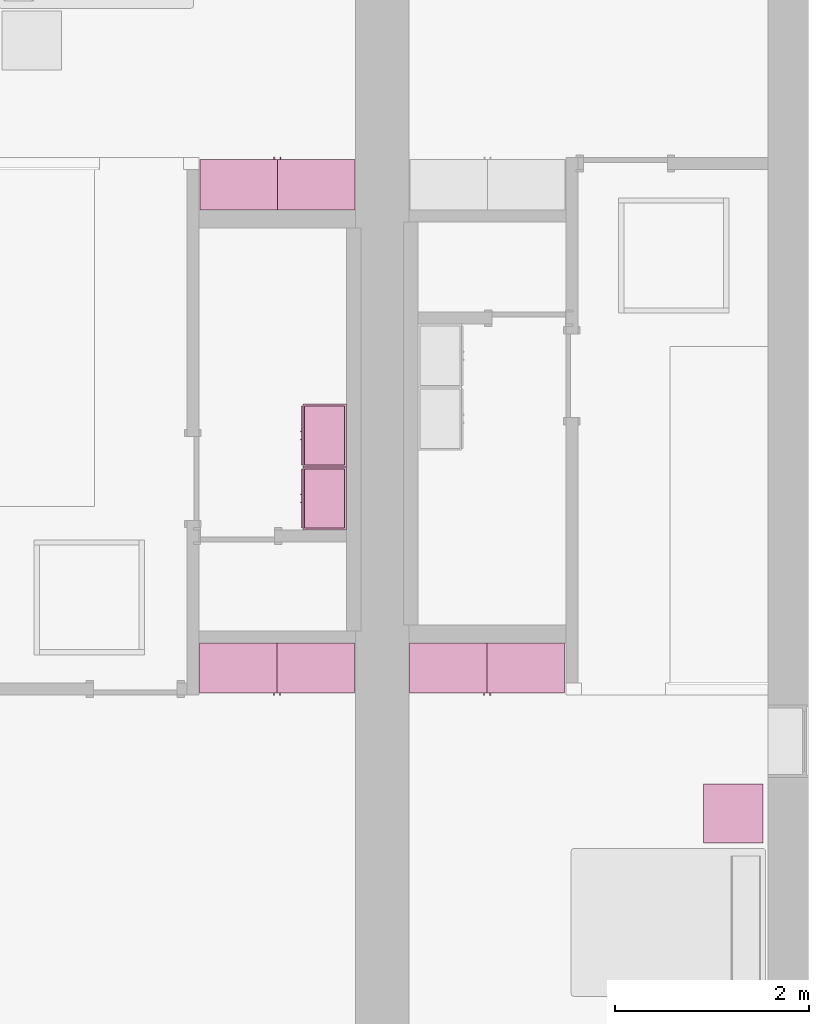
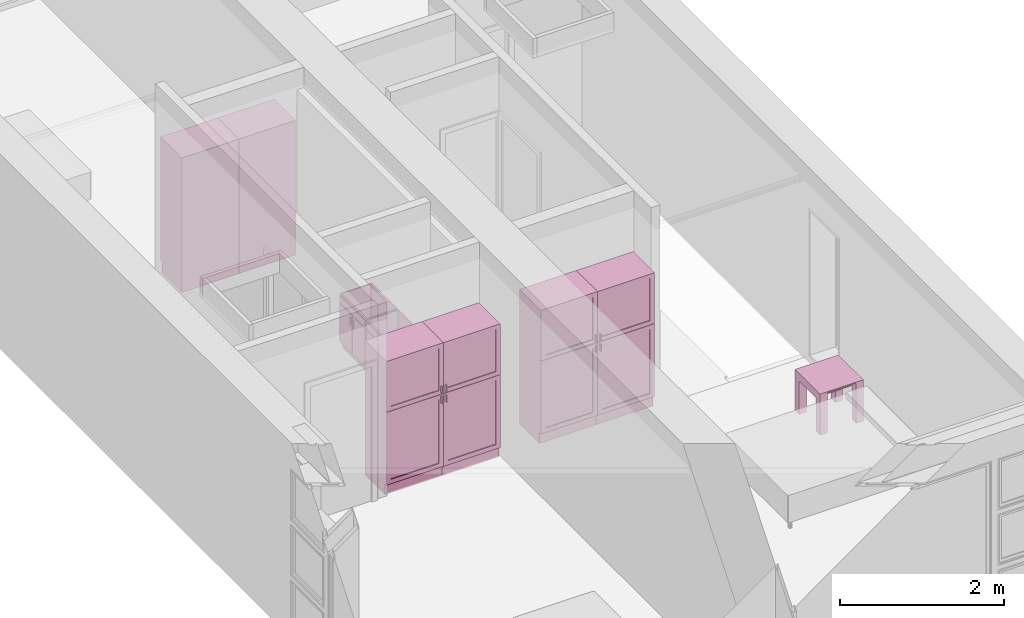
# One storey, part 10 of 14: 9 furnishings, 6 openings.
"""IFC2X3 building model written with IfcOpenShell, lengths in metres."""

from ifc_helpers import new_model, entity, si_unit, converted_unit, frame, origin, origin_2d_with_axis, place, context, project, spatial, polyline, rectangle, outline, extrude, face_set, surface_model, source, transform, mapped, type_object, type_shapes, element, save


model = new_model("IFC2X3")

# Units and contexts
model_context = context("Model", 3, precision=1e-09, world=origin())
plan_context = context("Plan", 3, precision=1e-09, world=origin())
ifc_project = project(units=[si_unit("LENGTHUNIT", "METRE"), si_unit("AREAUNIT", "SQUARE_METRE"), si_unit("VOLUMEUNIT", "CUBIC_METRE"), converted_unit("PLANEANGLEUNIT", "DEGREE", entity("IfcRatioMeasure", 0.01745329251994328), si_unit("PLANEANGLEUNIT", "RADIAN"), dimensions=[0, 0, 0, 0, 0, 0, 0]), si_unit("TIMEUNIT", "SECOND")], contexts=[model_context, plan_context])

# Site, building, storey, space
site_placement = place(None, origin())
site = spatial("IfcSite", under=ifc_project, at=site_placement, CompositionType="ELEMENT")
building_placement = place(site_placement, origin())
building = spatial("IfcBuilding", under=site, at=building_placement, CompositionType="ELEMENT")
storey_placement = place(building_placement, frame((0.0, 0.0, 3.100000000000378)))
storey = spatial("IfcBuildingStorey", under=building, at=storey_placement, Name="Level 2", CompositionType="ELEMENT", Elevation=3.100000000000378)
space_1_placement = place(storey_placement, origin())
space_1 = spatial("IfcSpace", under=storey, at=space_1_placement, CompositionType="ELEMENT", InteriorOrExteriorSpace="INTERNAL")

# Furnishing
furniture_type_1 = type_object("IfcFurnitureType", Name="0610 x 0610 x 0610mm", AssemblyPlace="NOTDEFINED")
shared_shape_1 = source(origin(), model_context, "Body", "SweptSolid", [
    extrude(rectangle(XDim=0.4067999999999992, YDim=0.4067999999999995, at=origin_2d_with_axis()), frame((0.01826576667263163, 0.09521107780222626, 0.4957000000000002), z_axis=(0.0, 0.0, 1.0), x_axis=(-1.0, 0.0, 0.0)), (0.0, 0.0, 1.0), 0.01270000000000002),
    extrude(outline(polyline([(-0.2732499999999937, -0.3050000000000002), (0.3240499999999779, -0.3050000000000002), (0.3240499999999779, 0.3049999999999985), (-0.2732499999999932, 0.3049999999999986), (-0.2732499999999932, 0.2034000000000015), (0.2224500000000091, 0.2034000000000015), (0.2224500000000091, -0.2033999999999998), (-0.2732499999999936, -0.2033999999999998), (-0.2732499999999937, -0.3050000000000002)])), frame((0.2216657666726329, 0.09521107780223541, 0.2732499999999923), z_axis=(1.0, 0.0, 0.0), x_axis=(0.0, 0.0, 1.0)), (0.0, 0.0, 1.0), 0.1016),
    extrude(outline(polyline([(-0.3050000000000043, -0.3240500000000255), (0.3049999999999944, -0.3240500000000255), (0.3049999999999944, 0.2732500000000109), (0.2034000000000044, 0.2732500000000109), (0.2034000000000044, -0.2224499999999962), (-0.2033999999999945, -0.2224499999999962), (-0.2033999999999945, 0.2732500000000109), (-0.3050000000000043, 0.2732500000000109), (-0.3050000000000043, -0.3240500000000255)])), frame((-0.2867342333273671, 0.09521107780222562, 0.2732500000000078), z_axis=(1.0, 0.0, 0.0), x_axis=(0.0, -1.0, 0.0)), (0.0, 0.0, 1.0), 0.1016),
    extrude(rectangle(XDim=0.4067999999999992, YDim=0.4067999999999995, at=origin_2d_with_axis()), frame((0.01826576667263163, 0.09521107780222593, 0.5973000000000002), z_axis=(0.0, 0.0, 1.0), x_axis=(-1.0, 0.0, 0.0)), (0.0, 0.0, 1.0), 0.01270000000000002),
    extrude(outline(polyline([(-0.3050000000000005, -0.3050000000000226), (0.3050000000000004, -0.3050000000000226), (0.3050000000000005, 0.3050000000000226), (-0.3050000000000004, 0.3050000000000226), (-0.3050000000000005, -0.3050000000000226)]), holes=[polyline([(-0.203399999999998, -0.2033999999999748), (-0.2033999999999979, 0.2034000000000246), (0.2034000000000013, 0.2034000000000245), (0.2034000000000012, -0.2033999999999749), (-0.203399999999998, -0.2033999999999748)])]), frame((0.01826576667263323, 0.09521107780225081, 0.5973000000000003), z_axis=(0.0, 0.0, 1.0), x_axis=(-1.0, 0.0, 0.0)), (0.0, 0.0, 1.0), 0.01269999999999996),
])
type_shapes(furniture_type_1, [shared_shape_1])
furnishing_1_placement = place(space_1_placement, frame((8.004734233327348, -12.98921107780223, 0.01899999999981805)))
element("IfcFurnishingElement", 1, at=furnishing_1_placement, inside=space_1, type_object=furniture_type_1, Name="M_Table-Coffee:0610 x 0610 x 0610mm:0610 x 0610 x 0610mm", ObjectType="0610 x 0610 x 0610mm", context=model_context, shape_type="MappedRepresentation", body=[
    mapped(shared_shape_1, transform((0.0, 0.0, 0.0), scale=1.0)),
])

# Space
space_2_placement = place(storey_placement, origin())
space_2 = spatial("IfcSpace", under=storey, at=space_2_placement, CompositionType="ELEMENT", InteriorOrExteriorSpace="INTERNAL")

# Furnishing, opening
furniture_type_2 = type_object("IfcFurnitureType", Name="800 mm", AssemblyPlace="NOTDEFINED")
shared_shape_2 = source(origin(), model_context, "Body", "SurfaceModel", [
    surface_model("IfcFaceBasedSurfaceModel", [(0.7999999999999998, 0.04444999999999991, 0.1615874999998423), (0.0, 0.04445000000000255, 0.1615874999998423), (0.0, 0.04445000000000255, 2.0), (0.7999999999999998, 0.04444999999999991, 2.0), (0.7809499999999974, 0.04444999999999998, 1.980949999999954), (0.01904999999999817, 0.04445000000000248, 1.980949999999954), (0.01904999999999817, 0.04445000000000248, 0.1806374999998427), (0.7809499999999974, 0.04444999999999998, 0.1806374999998428), (0.0, 0.5454000000000022, 2.0), (0.8000000000000014, 0.5453999999999996, 2.0), (0.8000000000000026, 0.5453999999999996, 0.0), (0.0, 0.5454000000000009, 0.0), (0.780949999999999, 0.5453999999999996, 1.980949999999954), (0.0190499999999998, 0.5454000000000021, 1.980949999999954), (0.0190499999999998, 0.5454000000000021, 0.1806374999998428), (0.780949999999999, 0.5453999999999996, 0.1806374999998428), (0.7999999999999999, 0.06040000000000177, 0.1615874999998423), (0.7999999999999999, 0.06040000000000177, 0.0), (0.0, 0.06040000000000177, 0.0), (0.0, 0.06040000000000177, 0.1615874999998318), (0.7745999999999997, 0.0, 1.371548036695815), (0.7745999999999997, 0.0, 1.269948036695815), (0.7620677683693553, 0.0, 1.269948036695815), (0.7620677683693553, 0.0, 1.371548036695815), (0.7745999999999988, 0.0, 1.219148036695816), (0.7745999999999988, 0.0, 1.117548036695818), (0.7620677683693542, 0.0, 1.117548036695818), (0.7620677683693542, 0.0, 1.219148036695816), (0.7745999999999998, 0.02539999999999998, 1.371548036695815), (0.7745999999999998, 0.02539999999999998, 1.269948036695815), (0.7620677683693555, 0.02540000000000005, 1.269948036695815), (0.7620677683693555, 0.02540000000000005, 1.371548036695815), (0.7745999999999988, 0.02539999999999998, 1.219148036695816), (0.7745999999999988, 0.02539999999999998, 1.117548036695818), (0.7620677683693542, 0.02540000000000005, 1.117548036695818), (0.7620677683693542, 0.02540000000000005, 1.219148036695816), (0.7364999999999996, 0.03810000000000007, 1.936499999999956), (0.7364999999999996, 0.03810000000000007, 1.308048036695816), (0.06350000000000126, 0.03810000000000231, 1.308048036695816), (0.06350000000000126, 0.03810000000000231, 1.936499999999956), (0.736499999999999, 0.03810000000000007, 1.181048036695814), (0.736499999999999, 0.03810000000000007, 0.2250874999998395), (0.06350000000000072, 0.03810000000000231, 0.2250874999998395), (0.06350000000000072, 0.03810000000000231, 1.181048036695814), (0.7364999999999996, 0.04445000000000005, 1.936499999999956), (0.7364999999999996, 0.04445000000000005, 1.308048036695816), (0.06350000000000126, 0.04445000000000228, 1.308048036695816), (0.06350000000000126, 0.04445000000000228, 1.936499999999956), (0.736499999999999, 0.04445000000000005, 1.181048036695814), (0.736499999999999, 0.04445000000000005, 0.2250874999998395), (0.06350000000000072, 0.04445000000000228, 0.2250874999998395), (0.06350000000000072, 0.04445000000000228, 1.181048036695814), (0.8, 0.02539999999999984, 2.0), (0.8, 0.02539999999999984, 1.247723036695813), (0.0, 0.02540000000000248, 1.247723036695813), (0.0, 0.02540000000000248, 2.0), (0.7364999999999996, 0.02540000000000005, 1.936499999999956), (0.0635000000000012, 0.02540000000000228, 1.936499999999956), (0.0635000000000012, 0.02540000000000228, 1.308048036695816), (0.7364999999999996, 0.02540000000000005, 1.308048036695816), (0.7999999999999998, 0.02539999999999984, 0.1615874999998214), (0.0, 0.02540000000000248, 0.1615874999998214), (0.0, 0.02540000000000248, 1.241373036695815), (0.7999999999999998, 0.02539999999999984, 1.241373036695815), (0.736499999999999, 0.02540000000000005, 1.181048036695817), (0.06350000000000065, 0.02540000000000228, 1.181048036695817), (0.06350000000000065, 0.02540000000000228, 0.2250874999998395), (0.736499999999999, 0.02540000000000005, 0.2250874999998395), (0.8000000000000002, 0.04444999999999984, 2.0), (0.8000000000000002, 0.04444999999999984, 1.247723036695813), (0.0, 0.04445000000000248, 1.247723036695813), (0.0, 0.04445000000000248, 2.0), (0.7999999999999999, 0.04444999999999984, 0.1615874999998214), (0.0, 0.04445000000000248, 0.1615874999998214), (0.0, 0.04445000000000248, 1.241373036695815), (0.7999999999999999, 0.04444999999999984, 1.241373036695815), (0.736499999999999, 0.04445000000000005, 1.181048036695817), (0.06350000000000072, 0.04445000000000228, 1.181048036695817), (0.7809499999999987, 0.5263500000000009, 1.980949999999952), (0.7809499999999988, 0.5263500000000009, 0.1806374999998463), (0.01904999999999987, 0.5263500000000009, 0.1806374999998463), (0.0190499999999998, 0.5263500000000009, 1.980949999999952), (0.7809499999999987, 0.5454000000000009, 1.980949999999952), (0.7809499999999987, 0.5454000000000009, 0.1806374999998463), (0.0190499999999998, 0.5454000000000009, 0.1806374999998463), (0.0190499999999998, 0.5454000000000009, 1.980949999999952)], [face_set([[[0, 1, 2, 3], [4, 5, 6, 7]], [[8, 9, 10, 11], [12, 13, 14, 15]], [[3, 0, 16, 17, 10, 9]], [[2, 8, 9, 3]], [[1, 2, 8, 11, 18, 19]], [[0, 1, 19, 16]], [[7, 15, 12, 4]], [[6, 14, 15, 7]], [[5, 13, 14, 6]], [[4, 5, 13, 12]], [[10, 17, 18, 11]], [[18, 19, 16, 17]]]), face_set([[[20, 21, 22, 23]], [[24, 25, 26, 27]], [[28, 29, 30, 31]], [[32, 33, 34, 35]], [[23, 31, 28, 20]], [[22, 23, 31, 30]], [[21, 22, 30, 29]], [[20, 28, 29, 21]], [[27, 35, 32, 24]], [[26, 27, 35, 34]], [[25, 26, 34, 33]], [[24, 32, 33, 25]]]), face_set([[[36, 37, 38, 39]], [[40, 41, 42, 43]], [[44, 45, 46, 47]], [[48, 49, 50, 51]], [[39, 47, 44, 36]], [[38, 46, 47, 39]], [[37, 38, 46, 45]], [[36, 37, 45, 44]], [[43, 51, 48, 40]], [[42, 50, 51, 43]], [[41, 42, 50, 49]], [[40, 41, 49, 48]]]), face_set([[[52, 53, 54, 55], [56, 57, 58, 59]], [[60, 61, 62, 63], [64, 65, 66, 67]], [[68, 69, 70, 71], [44, 47, 46, 45]], [[72, 73, 74, 75], [76, 77, 50, 49]], [[55, 71, 68, 52]], [[54, 55, 71, 70]], [[53, 54, 70, 69]], [[52, 53, 69, 68]], [[63, 60, 72, 75]], [[62, 74, 75, 63]], [[61, 62, 74, 73]], [[60, 61, 73, 72]], [[59, 45, 44, 56]], [[58, 46, 45, 59]], [[57, 58, 46, 47]], [[56, 57, 47, 44]], [[67, 49, 76, 64]], [[66, 50, 49, 67]], [[65, 66, 50, 77]], [[64, 65, 77, 76]]]), face_set([[[78, 79, 80, 81]], [[82, 83, 84, 85]], [[81, 85, 82, 78]], [[80, 81, 85, 84]], [[79, 80, 84, 83]], [[78, 79, 83, 82]]])]),
])
type_shapes(furniture_type_2, [shared_shape_2])
furnishing_2_placement = place(space_2_placement, frame((2.513999999999991, -11.6794, 0.0)))
furnishing_2 = element("IfcFurnishingElement", 2, at=furnishing_2_placement, inside=space_2, type_object=furniture_type_2, ObjectType="800 mm", context=model_context, shape_type="MappedRepresentation", body=[
    mapped(shared_shape_2, transform((0.0, 0.0, 0.0), scale=1.0)),
])
opening_1_placement = place(space_2_placement, frame((2.513999999999991, -11.6794, 0.0)))
element("IfcOpeningElement", 3, at=opening_1_placement, cuts=furnishing_2, ObjectType="Opening", context=model_context, shape_type="SweptSolid", body=[
    extrude(rectangle(XDim=1.800312500000111, YDim=0.7618999999999992, at=origin_2d_with_axis()), frame((0.01873770491802348, -0.5009499999999997, -2.01920625000048), z_axis=(0.0, 1.0, 0.0), x_axis=(0.0, 0.0, -1.0)), (0.0, 0.0, 1.0), 0.5009499999999997),
])

furniture_type_3 = type_object("IfcFurnitureType", Name="800 mm", AssemblyPlace="NOTDEFINED")
type_shapes(furniture_type_3, [shared_shape_2])
furnishing_3_placement = place(space_1_placement, frame((4.682999999999983, -11.67940000000001, 0.0)))
furnishing_3 = element("IfcFurnishingElement", 4, at=furnishing_3_placement, inside=space_1, type_object=furniture_type_3, ObjectType="800 mm", context=model_context, shape_type="MappedRepresentation", body=[
    mapped(shared_shape_2, transform((0.0, 0.0, 0.0), scale=1.0)),
])
opening_2_placement = place(space_1_placement, frame((4.682999999999983, -11.67940000000001, 0.0)))
element("IfcOpeningElement", 5, at=opening_2_placement, cuts=furnishing_3, ObjectType="Opening", context=model_context, shape_type="SweptSolid", body=[
    extrude(rectangle(XDim=1.800312500000111, YDim=0.7618999999999992, at=origin_2d_with_axis()), frame((0.01873770491802348, -0.5009499999999997, -2.01920625000048), z_axis=(0.0, 1.0, 0.0), x_axis=(0.0, 0.0, -1.0)), (0.0, 0.0, 1.0), 0.5009499999999997),
])

# Space
space_3_placement = place(storey_placement, origin())
space_3 = spatial("IfcSpace", under=storey, at=space_3_placement, CompositionType="ELEMENT", InteriorOrExteriorSpace="INTERNAL")

# Furnishing, opening
furniture_type_4 = type_object("IfcFurnitureType", Name="800 mm", AssemblyPlace="NOTDEFINED")
type_shapes(furniture_type_4, [shared_shape_2])
furnishing_4_placement = place(space_3_placement, frame((4.116999999999995, -6.120600000000001, 0.0), z_axis=(0.0, 0.0, 1.0), x_axis=(-1.0, 0.0, 0.0)))
furnishing_4 = element("IfcFurnishingElement", 6, at=furnishing_4_placement, inside=space_3, type_object=furniture_type_4, ObjectType="800 mm", context=model_context, shape_type="MappedRepresentation", body=[
    mapped(shared_shape_2, transform((0.0, 0.0, 0.0), scale=1.0)),
])
opening_3_placement = place(space_3_placement, frame((4.116999999999995, -6.120600000000001, 0.0), z_axis=(0.0, 0.0, 1.0), x_axis=(-1.0, 0.0, 0.0)))
element("IfcOpeningElement", 7, at=opening_3_placement, cuts=furnishing_4, ObjectType="Opening", context=model_context, shape_type="SweptSolid", body=[
    extrude(rectangle(XDim=1.800312500000111, YDim=0.7618999999999992, at=origin_2d_with_axis()), frame((-0.01873770491802666, 0.5009499999999996, -2.01920625000048), z_axis=(0.0, -1.0, 0.0), x_axis=(0.0, 0.0, -1.0)), (0.0, 0.0, 1.0), 0.5009499999999997),
])

furniture_type_5 = type_object("IfcFurnitureType", Name="800 mm", AssemblyPlace="NOTDEFINED")
shared_shape_3 = source(origin(), model_context, "Body", "SurfaceModel", [
    surface_model("IfcFaceBasedSurfaceModel", [(0.7999999999999998, 0.5009500000000022, 0.1615874999998423), (0.7999999999999998, 0.5009500000000022, 2.0), (0.0, 0.5009499999999997, 2.0), (0.0, 0.5009499999999997, 0.1615874999998423), (0.7809499999999974, 0.5009500000000022, 1.980949999999954), (0.7809499999999974, 0.5009500000000022, 0.1806374999998428), (0.01904999999999817, 0.5009499999999997, 0.1806374999998428), (0.01904999999999817, 0.5009499999999997, 1.980949999999954), (0.0, 0.0, 2.0), (0.0, 0.0, 0.0), (0.8000000000000026, 0.0, 0.0), (0.8000000000000014, 0.0, 2.0), (0.780949999999999, 0.0, 1.980949999999954), (0.780949999999999, 0.0, 0.1806374999998428), (0.0190499999999998, 0.0, 0.1806374999998427), (0.0190499999999998, 0.0, 1.980949999999954), (0.8000000000000026, 0.4850000000000004, 0.0), (0.7999999999999999, 0.4850000000000004, 0.1615874999998318), (0.0, 0.4850000000000004, 0.0), (0.0, 0.4850000000000004, 0.1615874999998423), (0.7745999999999997, 0.5454000000000022, 1.371548036695815), (0.7620677683693553, 0.5454000000000021, 1.371548036695815), (0.7620677683693553, 0.5454000000000021, 1.269948036695815), (0.7745999999999997, 0.5454000000000022, 1.269948036695815), (0.7745999999999988, 0.5454000000000022, 1.219148036695816), (0.7620677683693542, 0.5454000000000021, 1.219148036695816), (0.7620677683693542, 0.5454000000000021, 1.117548036695818), (0.7745999999999988, 0.5454000000000022, 1.117548036695818), (0.7745999999999998, 0.5200000000000022, 1.371548036695815), (0.7620677683693555, 0.5200000000000021, 1.371548036695815), (0.7620677683693555, 0.5200000000000021, 1.269948036695815), (0.7745999999999998, 0.5200000000000022, 1.269948036695815), (0.7745999999999988, 0.5200000000000022, 1.219148036695816), (0.7620677683693542, 0.5200000000000021, 1.219148036695816), (0.7620677683693542, 0.5200000000000021, 1.117548036695818), (0.7745999999999988, 0.5200000000000022, 1.117548036695818), (0.7364999999999996, 0.5073000000000021, 1.936499999999956), (0.06350000000000126, 0.5072999999999999, 1.936499999999956), (0.06350000000000126, 0.5072999999999999, 1.308048036695816), (0.7364999999999996, 0.5073000000000021, 1.308048036695816), (0.736499999999999, 0.5073000000000021, 1.181048036695814), (0.06350000000000072, 0.5072999999999999, 1.181048036695814), (0.06350000000000072, 0.5072999999999999, 0.2250874999998395), (0.736499999999999, 0.5073000000000021, 0.2250874999998395), (0.7364999999999996, 0.5009500000000021, 1.936499999999956), (0.06350000000000126, 0.5009499999999999, 1.936499999999956), (0.06350000000000126, 0.5009499999999999, 1.308048036695816), (0.7364999999999996, 0.5009500000000021, 1.308048036695816), (0.736499999999999, 0.5009500000000021, 1.181048036695814), (0.06350000000000072, 0.5009499999999999, 1.181048036695814), (0.06350000000000072, 0.5009499999999999, 0.2250874999998395), (0.736499999999999, 0.5009500000000021, 0.2250874999998395), (0.8, 0.5200000000000023, 2.0), (0.0, 0.5199999999999997, 2.0), (0.0, 0.5199999999999997, 1.247723036695813), (0.8, 0.5200000000000023, 1.247723036695813), (0.7364999999999996, 0.5200000000000021, 1.936499999999956), (0.7364999999999996, 0.5200000000000021, 1.308048036695816), (0.0635000000000012, 0.5199999999999999, 1.308048036695816), (0.0635000000000012, 0.5199999999999999, 1.936499999999956), (0.7999999999999998, 0.5200000000000023, 0.1615874999998214), (0.7999999999999998, 0.5200000000000023, 1.241373036695815), (0.0, 0.5199999999999997, 1.241373036695815), (0.0, 0.5199999999999997, 0.1615874999998214), (0.736499999999999, 0.5200000000000021, 1.181048036695817), (0.736499999999999, 0.5200000000000021, 0.2250874999998395), (0.06350000000000065, 0.5199999999999999, 0.2250874999998395), (0.06350000000000065, 0.5199999999999999, 1.181048036695817), (0.8000000000000002, 0.5009500000000023, 2.0), (0.0, 0.5009499999999997, 1.247723036695813), (0.8, 0.5009500000000023, 1.247723036695813), (0.7999999999999999, 0.5009500000000023, 0.1615874999998214), (0.7999999999999999, 0.5009500000000023, 1.241373036695815), (0.0, 0.5009499999999997, 1.241373036695815), (0.0, 0.5009499999999997, 0.1615874999998214), (0.736499999999999, 0.5009500000000021, 1.181048036695817), (0.06350000000000072, 0.5009499999999999, 1.181048036695817), (0.7809499999999987, 0.01905000000000129, 1.980949999999952), (0.0190499999999998, 0.01905000000000129, 1.980949999999952), (0.0190499999999998, 0.01905000000000129, 0.1806374999998463), (0.7809499999999987, 0.01905000000000129, 0.1806374999998463), (0.7809499999999987, 0.0, 1.980949999999952), (0.0190499999999998, 0.0, 1.980949999999952), (0.01904999999999987, 0.0, 0.1806374999998463), (0.7809499999999988, 0.0, 0.1806374999998463)], [face_set([[[0, 1, 2, 3], [4, 5, 6, 7]], [[8, 9, 10, 11], [12, 13, 14, 15]], [[1, 11, 10, 16, 17, 0]], [[2, 1, 11, 8]], [[3, 2, 8, 9, 18, 19]], [[0, 17, 19, 3]], [[5, 4, 12, 13]], [[6, 5, 13, 14]], [[7, 6, 14, 15]], [[4, 12, 15, 7]], [[10, 9, 18, 16]], [[18, 16, 17, 19]]]), face_set([[[20, 21, 22, 23]], [[24, 25, 26, 27]], [[28, 29, 30, 31]], [[32, 33, 34, 35]], [[21, 20, 28, 29]], [[22, 30, 29, 21]], [[23, 31, 30, 22]], [[20, 23, 31, 28]], [[25, 24, 32, 33]], [[26, 34, 33, 25]], [[27, 35, 34, 26]], [[24, 27, 35, 32]]]), face_set([[[36, 37, 38, 39]], [[40, 41, 42, 43]], [[44, 45, 46, 47]], [[48, 49, 50, 51]], [[37, 36, 44, 45]], [[38, 37, 45, 46]], [[39, 47, 46, 38]], [[36, 44, 47, 39]], [[41, 40, 48, 49]], [[42, 41, 49, 50]], [[43, 51, 50, 42]], [[40, 48, 51, 43]]]), face_set([[[52, 53, 54, 55], [56, 57, 58, 59]], [[60, 61, 62, 63], [64, 65, 66, 67]], [[68, 2, 69, 70], [44, 47, 46, 45]], [[71, 72, 73, 74], [75, 51, 50, 76]], [[53, 52, 68, 2]], [[54, 69, 2, 53]], [[55, 70, 69, 54]], [[52, 68, 70, 55]], [[61, 72, 71, 60]], [[62, 61, 72, 73]], [[63, 74, 73, 62]], [[60, 71, 74, 63]], [[57, 56, 44, 47]], [[58, 57, 47, 46]], [[59, 45, 46, 58]], [[56, 44, 45, 59]], [[65, 64, 75, 51]], [[66, 65, 51, 50]], [[67, 76, 50, 66]], [[64, 75, 76, 67]]]), face_set([[[77, 78, 79, 80]], [[81, 82, 83, 84]], [[78, 77, 81, 82]], [[79, 83, 82, 78]], [[80, 84, 83, 79]], [[77, 81, 84, 80]]])]),
])
type_shapes(furniture_type_5, [shared_shape_3])
furnishing_5_placement = place(space_1_placement, frame((6.282999999999985, -11.13400000000001, 0.0), z_axis=(0.0, 0.0, 1.0), x_axis=(-1.0, 0.0, 0.0)))
furnishing_5 = element("IfcFurnishingElement", 8, at=furnishing_5_placement, inside=space_1, type_object=furniture_type_5, ObjectType="800 mm", context=model_context, shape_type="MappedRepresentation", body=[
    mapped(shared_shape_3, transform((0.0, 0.0, 0.0), scale=1.0)),
])
opening_4_placement = place(space_1_placement, frame((6.282999999999985, -11.13400000000001, 0.0), z_axis=(0.0, 0.0, 1.0), x_axis=(-1.0, 0.0, 0.0)))
element("IfcOpeningElement", 9, at=opening_4_placement, cuts=furnishing_5, ObjectType="Opening", context=model_context, shape_type="SweptSolid", body=[
    extrude(rectangle(XDim=1.800312500000111, YDim=0.7618999999999992, at=origin_2d_with_axis()), frame((-0.01873770491802511, 0.0, -2.01920625000048), z_axis=(0.0, -1.0, 0.0), x_axis=(0.0, 0.0, -1.0)), (0.0, 0.0, 1.0), 0.5009499999999997),
])

furniture_type_6 = type_object("IfcFurnitureType", Name="800 mm", AssemblyPlace="NOTDEFINED")
type_shapes(furniture_type_6, [shared_shape_3])
furnishing_6_placement = place(space_2_placement, frame((4.113999999999993, -11.134, 0.0), z_axis=(0.0, 0.0, 1.0), x_axis=(-1.0, 0.0, 0.0)))
furnishing_6 = element("IfcFurnishingElement", 10, at=furnishing_6_placement, inside=space_2, type_object=furniture_type_6, ObjectType="800 mm", context=model_context, shape_type="MappedRepresentation", body=[
    mapped(shared_shape_3, transform((0.0, 0.0, 0.0), scale=1.0)),
])
opening_5_placement = place(space_2_placement, frame((4.113999999999993, -11.134, 0.0), z_axis=(0.0, 0.0, 1.0), x_axis=(-1.0, 0.0, 0.0)))
element("IfcOpeningElement", 11, at=opening_5_placement, cuts=furnishing_6, ObjectType="Opening", context=model_context, shape_type="SweptSolid", body=[
    extrude(rectangle(XDim=1.800312500000111, YDim=0.7618999999999992, at=origin_2d_with_axis()), frame((-0.01873770491802511, 0.0, -2.01920625000048), z_axis=(0.0, -1.0, 0.0), x_axis=(0.0, 0.0, -1.0)), (0.0, 0.0, 1.0), 0.5009499999999997),
])

furniture_type_7 = type_object("IfcFurnitureType", Name="800 mm", AssemblyPlace="NOTDEFINED")
type_shapes(furniture_type_7, [shared_shape_3])
furnishing_7_placement = place(space_3_placement, frame((2.51699999999999, -6.665999999999991, 0.0)))
furnishing_7 = element("IfcFurnishingElement", 12, at=furnishing_7_placement, inside=space_3, type_object=furniture_type_7, ObjectType="800 mm", context=model_context, shape_type="MappedRepresentation", body=[
    mapped(shared_shape_3, transform((0.0, 0.0, 0.0), scale=1.0)),
])
opening_6_placement = place(space_3_placement, frame((2.51699999999999, -6.665999999999991, 0.0)))
element("IfcOpeningElement", 13, at=opening_6_placement, cuts=furnishing_7, ObjectType="Opening", context=model_context, shape_type="SweptSolid", body=[
    extrude(rectangle(XDim=1.800312500000111, YDim=0.7618999999999992, at=origin_2d_with_axis()), frame((0.01873770491802511, 0.0, -2.01920625000048), z_axis=(0.0, 1.0, 0.0), x_axis=(0.0, 0.0, -1.0)), (0.0, 0.0, 1.0), 0.5009499999999997),
])

# Space
space_4_placement = place(storey_placement, origin())
space_4 = spatial("IfcSpace", under=storey, at=space_4_placement, CompositionType="ELEMENT", InteriorOrExteriorSpace="INTERNAL")

# Furnishings
furniture_type_8 = type_object("IfcFurnitureType", Name="650 x 450 mm", AssemblyPlace="NOTDEFINED")
shared_shape_4 = source(origin(), model_context, "Body", "SurfaceModel", [
    surface_model("IfcFaceBasedSurfaceModel", [(0.6309500000000011, 0.04444999999999903, 0.8199999999999998), (0.6309500000000011, 0.04444999999999903, 0.09999999999999946), (0.01904999999999871, 0.04444999999999903, 0.09999999999999946), (0.01904999999999871, 0.04444999999999903, 0.8199999999999998), (0.6499999999999999, 0.02540000000000032, 0.8199999999999998), (0.0, 0.02540000000000032, 0.8199999999999998), (0.6499999999999999, 0.02540000000000032, 0.09999999999999946), (0.0, 0.02540000000000032, 0.09999999999999946), (0.01904999999999871, 0.4563500000000013, 0.8199999999999998), (0.01904999999999871, 0.4563500000000013, 0.09999999999999944), (0.01904999999999871, 0.06040000000000224, 0.09999999999999946), (0.0, 0.4754, 0.8199999999999998), (0.0, 0.4754, 0.0), (0.0, 0.06040000000000224, 0.0), (0.0, 0.06040000000000224, 0.09999999999999944), (0.6309500000000011, 0.4563500000000013, 0.8199999999999998), (0.6309500000000011, 0.4563500000000013, 0.09999999999999944), (0.6499999999999998, 0.4754, 0.8199999999999998), (0.6499999999999999, 0.4754, 0.0), (0.6309500000000011, 0.06040000000000224, 0.09999999999999944), (0.6499999999999999, 0.06040000000000224, 0.09999999999999946), (0.6499999999999999, 0.06040000000000224, 0.0), (0.2900749999999994, 0.0, 0.6422000000000013), (0.2900749999999994, 0.0, 0.5174698950351613), (0.2773749999999991, 0.0, 0.5174698950351613), (0.2773749999999991, 0.0, 0.6422000000000013), (0.3726249999999207, 0.0, 0.6422000000000011), (0.3726249999999207, 0.0, 0.5174698950351634), (0.3599249999999205, 0.0, 0.5174698950351634), (0.3599249999999205, 0.0, 0.6422000000000011), (0.2900749999999994, 0.01270000000000029, 0.6422000000000013), (0.2900749999999994, 0.01270000000000029, 0.5174698950351613), (0.2773749999999991, 0.01270000000000036, 0.5174698950351613), (0.2773749999999991, 0.01270000000000036, 0.6422000000000013), (0.3726249999999207, 0.01270000000000002, 0.6422000000000011), (0.3726249999999207, 0.01270000000000002, 0.5174698950351634), (0.3599249999999206, 0.01270000000000009, 0.5174698950351634), (0.3599249999999206, 0.01270000000000009, 0.6422000000000011), (0.3154749999998973, 0.01270000000000029, 0.6803000000000058), (0.3154749999998973, 0.01270000000000029, 0.1190499999998422), (0.01905000000047931, 0.01270000000000124, 0.1190499999998422), (0.01905000000047931, 0.01270000000000124, 0.6803000000000058), (0.6309500000005075, 0.01269999999999928, 0.6803000000000425), (0.6309500000005075, 0.01269999999999928, 0.1190499999998571), (0.3345249999998469, 0.01270000000000023, 0.1190499999998571), (0.3345249999998469, 0.01270000000000023, 0.6803000000000425), (0.6309500000005104, 0.01269999999999928, 0.8009500000000862), (0.6309500000005104, 0.01269999999999928, 0.699350000000061), (0.01905000000049125, 0.01270000000000124, 0.699350000000061), (0.01905000000049122, 0.01270000000000124, 0.8009500000000862), (0.3154749999998973, 0.02540000000000032, 0.6803000000000058), (0.3154749999998973, 0.02540000000000032, 0.1190499999998422), (0.01905000000047934, 0.02540000000000127, 0.1190499999998422), (0.01905000000047934, 0.02540000000000127, 0.6803000000000058), (0.6309500000005075, 0.0253999999999993, 0.6803000000000425), (0.6309500000005075, 0.0253999999999993, 0.1190499999998571), (0.3345249999998469, 0.02540000000000025, 0.1190499999998571), (0.3345249999998469, 0.02540000000000025, 0.6803000000000425), (0.6309500000005104, 0.0253999999999993, 0.8009500000000862), (0.6309500000005104, 0.0253999999999993, 0.699350000000061), (0.01905000000049135, 0.02540000000000127, 0.699350000000061), (0.01905000000049129, 0.02540000000000127, 0.8009500000000862), (0.6309500000000011, 0.4563500000000013, 0.119049999999842), (0.6309500000000011, 0.04444999999999903, 0.119049999999842), (0.01904999999999871, 0.04444999999999903, 0.119049999999842), (0.01904999999999871, 0.4563500000000013, 0.119049999999842), (0.6309500000000011, 0.04444999999999903, 0.09999999999999944), (0.01904999999999871, 0.04444999999999903, 0.09999999999999944)], [face_set([[[0, 1, 2, 3]], [[0, 4, 5, 3]], [[4, 6, 7, 5]], [[2, 1, 6, 7]], [[3, 8, 9, 10, 2]], [[5, 11, 8, 3]], [[7, 5, 11, 12, 13, 14]], [[2, 7, 14, 10]], [[8, 15, 16, 9]], [[11, 17, 15, 8]], [[12, 11, 17, 18]], [[1, 19, 16, 15, 0]], [[0, 15, 17, 4]], [[4, 6, 20, 21, 18, 17]], [[6, 1, 19, 20]], [[10, 9, 16, 19]], [[18, 21, 13, 12]], [[13, 14, 10, 19, 20, 21]]]), face_set([[[22, 23, 24, 25]], [[26, 27, 28, 29]], [[30, 31, 32, 33]], [[34, 35, 36, 37]], [[25, 33, 30, 22]], [[24, 32, 33, 25]], [[23, 24, 32, 31]], [[22, 23, 31, 30]], [[29, 37, 34, 26]], [[28, 36, 37, 29]], [[27, 28, 36, 35]], [[26, 27, 35, 34]]]), face_set([[[38, 39, 40, 41]], [[42, 43, 44, 45]], [[46, 47, 48, 49]], [[50, 51, 52, 53]], [[54, 55, 56, 57]], [[58, 59, 60, 61]], [[41, 53, 50, 38]], [[40, 41, 53, 52]], [[39, 40, 52, 51]], [[38, 39, 51, 50]], [[45, 57, 54, 42]], [[44, 56, 57, 45]], [[43, 44, 56, 55]], [[42, 43, 55, 54]], [[49, 61, 58, 46]], [[48, 49, 61, 60]], [[47, 48, 60, 59]], [[46, 47, 59, 58]]]), face_set([[[62, 63, 64, 65]], [[16, 66, 67, 9]], [[65, 62, 16, 9]], [[64, 65, 9, 67]], [[63, 66, 67, 64]], [[62, 63, 66, 16]]])]),
])
type_shapes(furniture_type_8, [shared_shape_4])
for number, where, z_axis, x_axis in (
    (14, (3.554599999999983, -9.32005117851059, 0.01299999999981782), (0.0, 0.0, 1.0), (0.0, -1.0, 0.0)),
    (15, (3.554599999999985, -8.67005117851059, 0.01299999999981782), (0.0, 0.0, 1.0), (0.0, -1.0, 0.0)),
):
    element("IfcFurnishingElement", number, at=place(space_4_placement, frame(where, z_axis=z_axis, x_axis=x_axis)), inside=space_4, type_object=furniture_type_8, ObjectType="650 x 450 mm", context=model_context, shape_type="MappedRepresentation", body=[
        mapped(shared_shape_4, transform((0.0, 0.0, 0.0), scale=1.0)),
    ])

save(model, "model.ifc")
